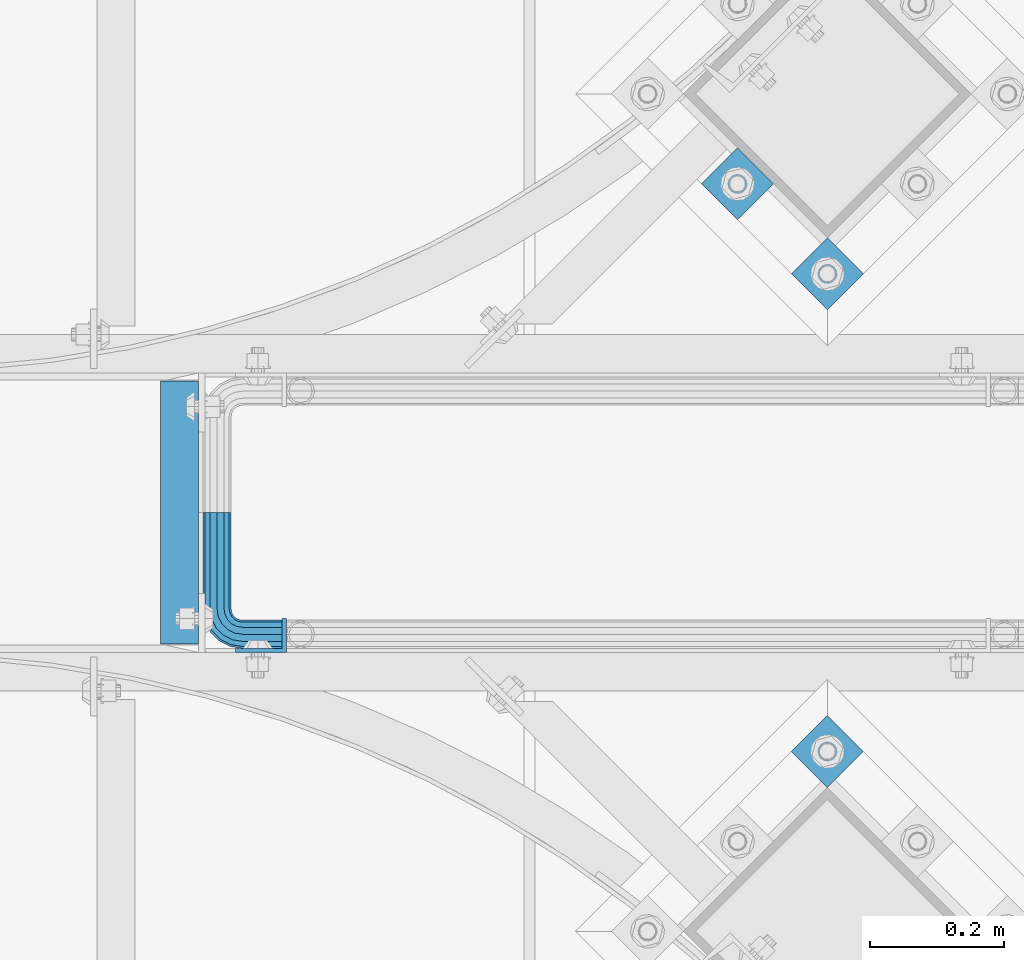
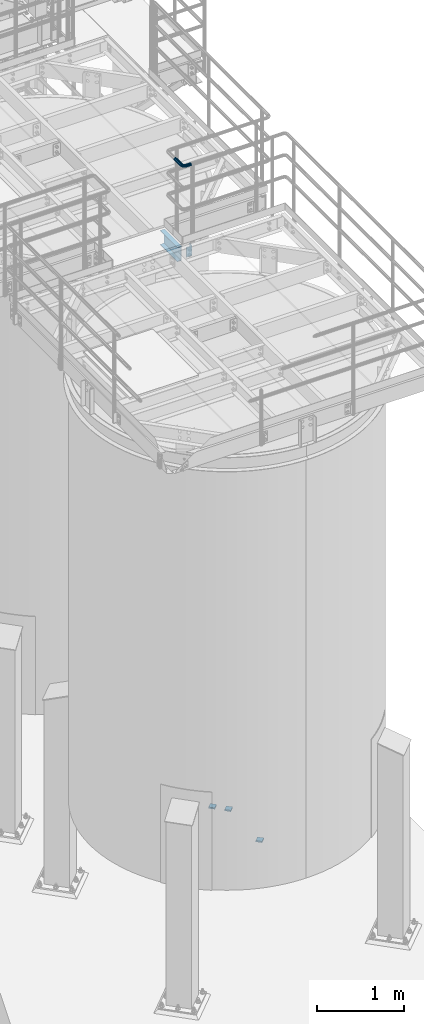
# One storey, part 1118 of 1876: 6 beams, 4 elements without a shape of their own.
"""IFC2X3 building model written with IfcOpenShell, lengths in millimetres."""

from ifc_helpers import new_model, si_unit, frame, origin_with_axes, place, context, subcontext, project, spatial, faceted_brep, material, type_object, element, aggregate, save


model = new_model("IFC2X3")

# Units and contexts
model_context = context("Model", 3, precision=1e-05, world=origin_with_axes())
body_context = subcontext(model_context, "Body", "Model", "MODEL_VIEW")
ifc_project = project(units=[si_unit("LENGTHUNIT", "METRE", prefix="MILLI"), si_unit("AREAUNIT", "SQUARE_METRE"), si_unit("VOLUMEUNIT", "CUBIC_METRE"), si_unit("MASSUNIT", "GRAM", prefix="KILO"), si_unit("TIMEUNIT", "SECOND"), si_unit("PLANEANGLEUNIT", "RADIAN"), si_unit("SOLIDANGLEUNIT", "STERADIAN"), si_unit("THERMODYNAMICTEMPERATUREUNIT", "DEGREE_CELSIUS"), si_unit("LUMINOUSINTENSITYUNIT", "LUMEN")], contexts=[model_context])

# Site, building, storey
site_placement = place(None, origin_with_axes())
site = spatial("IfcSite", under=ifc_project, at=site_placement, CompositionType="ELEMENT")
building_placement = place(site_placement, origin_with_axes())
building = spatial("IfcBuilding", under=site, at=building_placement, Name="Undefined", CompositionType="ELEMENT")
storey_placement = place(building_placement, origin_with_axes())
storey = spatial("IfcBuildingStorey", under=building, at=storey_placement, Name="Undefined", CompositionType="ELEMENT", Elevation=0.0)

# Assembly, beams
assembly_1_placement = place(storey_placement, origin_with_axes())
assembly_1 = element("IfcElementAssembly", 1, at=assembly_1_placement, inside=storey, Name="HANDRAIL", AssemblyPlace="NOTDEFINED", PredefinedType="RIGID_FRAME")
ifc_material_1 = material()
beam_type_1 = type_object("IfcBeamType", Name="PIPE1-1/4STD", PredefinedType="NOTDEFINED")
beam_1_placement = place(assembly_1_placement, frame((5666.23343150122, -11563.31485742, 9090.025), z_axis=(0.0, 0.0, -1.0), x_axis=(0.0, -1.0, 0.0)))
beam_1 = element("IfcBeam", 2, at=beam_1_placement, type_object=beam_type_1, material=ifc_material_1, Name="HANDRAIL", ObjectType="PIPE1-1/4STD", context=body_context, shape_type="Brep", body=[
    faceted_brep([(9.09494701772928e-13, -21.0820000000003, 0.0), (0.0, -18.2575475625836, -10.5409999999993), (144.017601013184, -18.2575475625854, -10.5409999999993), (144.017601013184, -21.0820000000012, 0.0), (0.0, -10.5410000000002, -18.2575475625836), (144.017601013184, -10.5410000000011, -18.2575475625836), (-4.28826751885936e-09, 0.0, -21.0820000000003), (144.017601013184, -1.81898940354586e-12, -21.0820000000003), (0.0, 10.5410000000002, -18.2575475625836), (144.017601013184, 10.5409999999983, -18.2575475625836), (0.0, 18.2575475625836, -10.5409999999993), (144.017601013184, 18.2575475625817, -10.5409999999993), (9.09494701772928e-13, 21.0820000000003, 0.0), (144.017601013184, 21.0819999999985, 0.0), (0.0, 18.2575475625836, 10.5409999999993), (144.017601013184, 18.2575475625817, 10.5409999999993), (0.0, 10.5410000000002, 18.2575475625836), (144.017601013184, 10.5409999999983, 18.2575475625836), (0.0, 0.0, 21.0820000000003), (144.017601013184, -1.81898940354586e-12, 21.0820000000003), (0.0, -10.5410000000002, 18.2575475625836), (144.017601013184, -10.5410000000011, 18.2575475625836), (0.0, -18.2575475625836, 10.5409999999993), (144.017601013184, -18.2575475625854, 10.5409999999993), (0.0, -17.5259999999998, 0.0), (0.0, -15.1779612267264, 8.76300000000083), (144.017601013184, -15.1779612267273, 8.76300000000083), (144.017601013184, -17.5260000000017, 0.0), (0.0, -8.76299999999992, 15.1779612267255), (144.017601013184, -8.76300000000174, 15.1779612267255), (0.0, 0.0, 17.5259999999998), (144.017601013184, -1.81898940354586e-12, 17.5259999999998), (0.0, 8.76299999999992, 15.1779612267255), (144.017601013184, 8.76299999999901, 15.1779612267255), (0.0, 15.1779612267264, 8.76300000000083), (144.017601013184, 15.1779612267246, 8.76300000000083), (0.0, 17.5259999999998, 0.0), (144.017601013184, 17.5259999999989, 0.0), (0.0, 15.1779612267264, -8.76300000000083), (144.017601013184, 15.1779612267246, -8.76300000000083), (0.0, 8.76299999999992, -15.1779612267255), (144.017601013184, 8.76299999999901, -15.1779612267255), (0.0, 0.0, -17.5259999999998), (144.017601013184, -1.81898940354586e-12, -17.5259999999998), (0.0, -8.76299999999992, -15.1779612267255), (144.017601013184, -8.76300000000174, -15.1779612267255), (0.0, -15.1779612267264, -8.76300000000083), (144.017601013184, -15.1779612267273, -8.76300000000083), (149.276451751935, -21.9149201310092, 0.0), (150.149255554901, -19.2287062354389, 10.5409999999993), (152.533799889643, -11.8898333927427, 18.2575475625836), (155.791148027351, -1.86474665447531, 21.0820000000003), (159.048496165058, 8.1603400837912, 18.2575475625836), (161.4330404998, 15.4992129264874, 10.5409999999993), (162.305844302766, 18.1854268220586, 0.0), (161.4330404998, 15.4992129264874, -10.5409999999993), (159.048496165058, 8.1603400837912, -18.2575475625836), (155.791148027351, -1.86474665447531, -21.0820000000003), (152.533799889643, -11.8898333927427, -18.2575475625836), (150.149255554901, -19.2287062354389, -10.5409999999993), (161.206979870767, 14.8034698501133, 0.0), (160.481395986375, 12.570352274277, 8.76300000000083), (158.499063949059, 6.46936159781853, 15.1779612267255), (155.791148027351, -1.86474665447531, 17.5259999999998), (153.083232105642, -10.1988549067692, 15.1779612267255), (151.100900068326, -16.2998455832276, 8.76300000000083), (150.375316183934, -18.5329631590639, 0.0), (151.100900068326, -16.2998455832276, -8.76300000000083), (153.083232105642, -10.1988549067701, -15.1779612267255), (155.791148027351, -1.86474665447531, -17.5259999999998), (158.499063949059, 6.46936159781853, -15.1779612267255), (160.481395986375, 12.570352274277, -8.76300000000083), (172.608062573056, 1.25139591480547, 18.2575475625836), (177.143735428957, 7.49421403083761, 10.5409999999993), (166.412218228641, -7.27645222290084, 21.0820000000003), (160.216373884225, -15.8043003606062, 18.2575475625836), (155.680701028325, -22.0471184766393, 10.5409999999993), (154.02052953981, -24.3321484983126, 0.0), (155.680701028325, -22.0471184766393, -10.5409999999993), (160.216373884225, -15.8043003606062, -18.2575475625836), (166.412218228641, -7.27645222290084, -21.0820000000003), (172.608062573056, 1.25139591480547, -18.2575475625836), (177.143735428957, 7.49421403083761, -10.5409999999993), (178.803906917472, 9.77924405251179, 0.0), (175.333599997579, 5.00277634948452, -8.76300000000083), (176.71374256032, 6.90237962051469, 0.0), (171.562980394479, -0.187036301193075, -15.1779612267255), (166.412218228641, -7.27645222290084, -17.5259999999998), (161.261456062801, -14.3658681446077, -15.1779612267255), (157.490836459703, -19.5556807952853, -8.76300000000083), (156.110693896962, -21.4552840663155, 0.0), (157.490836459703, -19.5556807952853, 8.76300000000083), (161.261456062801, -14.3658681446077, 15.1779612267255), (166.412218228641, -7.27645222290084, 17.5259999999998), (171.562980394479, -0.187036301193075, 15.1779612267255), (175.333599997579, 5.00277634948452, 8.76300000000083), (183.368995402116, -9.50953691425457, 18.2575475625836), (189.611813518148, -4.97386405835459, 10.5409999999993), (174.841147264409, -15.7053812586691, 21.0820000000003), (166.313299126703, -21.9012256030846, 18.2575475625836), (160.070481010669, -26.4368984589846, 10.5409999999993), (157.785450988997, -28.0970699474992, 0.0), (160.070481010669, -26.4368984589846, -10.5409999999993), (166.313299126703, -21.9012256030846, -18.2575475625836), (174.841147264409, -15.7053812586691, -21.0820000000003), (183.368995402116, -9.50953691425457, -18.2575475625836), (189.611813518148, -4.97386405835459, -10.5409999999993), (191.896843539822, -3.31369256983999, 0.0), (187.120375836796, -6.78399948973311, -8.76300000000083), (189.019979107825, -5.40385692699238, 0.0), (181.930563186117, -10.5546190928308, -15.1779612267255), (174.841147264409, -15.7053812586691, -17.5259999999998), (167.751731342702, -20.8561434245084, -15.1779612267255), (162.561918692023, -24.6267630276061, -8.76300000000083), (160.662315420994, -26.0069055903468, 0.0), (162.561918692023, -24.6267630276061, 8.76300000000083), (167.751731342702, -20.8561434245084, 15.1779612267255), (174.841147264409, -15.7053812586691, 17.5259999999998), (181.930563186117, -10.5546190928308, 15.1779612267255), (187.120375836796, -6.78399948973311, 8.76300000000083), (190.277939571099, -23.0691033222465, 18.2575475625836), (197.616812413795, -20.6845589875047, 10.5409999999993), (180.252852832831, -26.3264514599541, 21.0820000000003), (170.227766094566, -29.5837995976626, 18.2575475625836), (162.888893251869, -31.9683439324044, 10.5409999999993), (160.202679356298, -32.8411477353702, 0.0), (162.888893251869, -31.9683439324044, -10.5409999999993), (170.227766094566, -29.5837995976626, -18.2575475625836), (180.252852832831, -26.3264514599541, -21.0820000000003), (190.277939571099, -23.0691033222465, -18.2575475625836), (197.616812413795, -20.6845589875047, -10.5409999999993), (200.303026309366, -19.811755184538, 0.0), (194.687951761583, -21.6362035009297, -8.76300000000083), (196.921069337421, -20.9106196165367, 0.0), (188.586961085126, -23.6185355382449, -15.1779612267255), (180.252852832831, -26.3264514599541, -17.5259999999998), (171.918744580538, -29.0343673816633, -15.1779612267255), (165.817753904079, -31.0166994189794, -8.76300000000083), (163.584636328244, -31.7422833033725, 0.0), (165.817753904079, -31.0166994189794, 8.76300000000083), (171.918744580538, -29.0343673816633, 15.1779612267255), (180.252852832831, -26.3264514599541, 17.5259999999998), (188.586961085126, -23.6185355382449, 15.1779612267255), (194.687951761583, -21.6362035009297, 8.76300000000083), (171.576599487307, -38.0999984741229, -18.2575475625836), (163.860051924723, -38.0999984741229, -10.5409999999993), (182.117599487307, -38.099998474122, -21.0820000000003), (192.658599487306, -38.099998474122, -18.2575475625836), (200.37514704989, -38.099998474122, -10.5409999999993), (203.199599487307, -38.099998474122, 0.0), (200.37514704989, -38.099998474122, 10.5409999999993), (192.658599487306, -38.099998474122, 18.2575475625836), (182.117599487307, -38.099998474122, 21.0820000000003), (171.576599487307, -38.0999984741229, 18.2575475625836), (163.860051924723, -38.0999984741229, 10.5409999999993), (161.035599487304, -38.0999984741229, 0.0), (197.295560714032, -38.099998474122, -8.76300000000083), (199.643599487306, -38.099998474122, 0.0), (190.880599487307, -38.099998474122, -15.1779612267255), (182.117599487307, -38.099998474122, -17.5259999999998), (173.354599487306, -38.0999984741229, -15.1779612267255), (166.939638260581, -38.0999984741229, -8.76300000000083), (164.591599487305, -38.0999984741229, 0.0), (166.939638260581, -38.0999984741229, 8.76300000000083), (173.354599487306, -38.0999984741229, 15.1779612267255), (182.117599487307, -38.099998474122, 17.5259999999998), (190.880599487307, -38.099998474122, 15.1779612267255), (197.295560714032, -38.099998474122, 8.76300000000083), (163.860051924721, -103.933624267578, -10.5409999999993), (161.035599487304, -103.933624267578, 0.0), (171.576599487305, -103.933624267578, -18.2575475625836), (182.117599487305, -103.933624267578, -21.0820000000003), (192.658599487304, -103.933624267578, -18.2575475625836), (200.375147049888, -103.933624267578, -10.5409999999993), (203.199599487305, -103.933624267578, 0.0), (200.375147049888, -103.933624267578, 10.5409999999993), (192.658599487304, -103.933624267578, 18.2575475625836), (182.117599487305, -103.933624267578, 21.0820000000003), (171.576599487305, -103.933624267578, 18.2575475625836), (163.860051924721, -103.933624267578, 10.5409999999993), (166.939638260579, -103.933624267578, 8.76300000000083), (164.591599487305, -103.933624267578, 0.0), (173.354599487304, -103.933624267578, 15.1779612267255), (182.117599487305, -103.933624267578, 17.5259999999998), (190.880599487306, -103.933624267578, 15.1779612267255), (197.29556071403, -103.933624267578, 8.76300000000083), (199.643599487305, -103.933624267578, 0.0), (197.29556071403, -103.933624267578, -8.76300000000083), (190.880599487306, -103.933624267578, -15.1779612267255), (182.117599487305, -103.933624267578, -17.5259999999998), (173.354599487304, -103.933624267578, -15.1779612267255), (166.939638260579, -103.933624267578, -8.76300000000083)], [[[0, 1, 2, 3]], [[1, 4, 5, 2]], [[4, 6, 7, 5]], [[6, 8, 9, 7]], [[8, 10, 11, 9]], [[10, 12, 13, 11]], [[12, 14, 15, 13]], [[14, 16, 17, 15]], [[16, 18, 19, 17]], [[18, 20, 21, 19]], [[20, 22, 23, 21]], [[22, 0, 3, 23]], [[24, 25, 26, 27]], [[25, 28, 29, 26]], [[28, 30, 31, 29]], [[30, 32, 33, 31]], [[32, 34, 35, 33]], [[34, 36, 37, 35]], [[36, 38, 39, 37]], [[38, 40, 41, 39]], [[40, 42, 43, 41]], [[42, 44, 45, 43]], [[44, 46, 47, 45]], [[46, 24, 27, 47]], [[22, 20, 18, 16, 14, 12, 10, 8, 6, 4, 1, 0], [46, 44, 42, 40, 38, 36, 34, 32, 30, 28, 25, 24]], [[23, 3, 48, 49]], [[21, 23, 49, 50]], [[19, 21, 50, 51]], [[17, 19, 51, 52]], [[15, 17, 52, 53]], [[13, 15, 53, 54]], [[11, 13, 54, 55]], [[9, 11, 55, 56]], [[7, 9, 56, 57]], [[5, 7, 57, 58]], [[2, 5, 58, 59]], [[3, 2, 59, 48]], [[35, 37, 60, 61]], [[33, 35, 61, 62]], [[31, 33, 62, 63]], [[29, 31, 63, 64]], [[26, 29, 64, 65]], [[27, 26, 65, 66]], [[47, 27, 66, 67]], [[45, 47, 67, 68]], [[43, 45, 68, 69]], [[41, 43, 69, 70]], [[39, 41, 70, 71]], [[37, 39, 71, 60]], [[52, 72, 73, 53]], [[51, 74, 72, 52]], [[50, 75, 74, 51]], [[49, 76, 75, 50]], [[48, 77, 76, 49]], [[59, 78, 77, 48]], [[58, 79, 78, 59]], [[57, 80, 79, 58]], [[56, 81, 80, 57]], [[55, 82, 81, 56]], [[54, 83, 82, 55]], [[53, 73, 83, 54]], [[71, 84, 85, 60]], [[70, 86, 84, 71]], [[69, 87, 86, 70]], [[68, 88, 87, 69]], [[67, 89, 88, 68]], [[66, 90, 89, 67]], [[65, 91, 90, 66]], [[64, 92, 91, 65]], [[63, 93, 92, 64]], [[62, 94, 93, 63]], [[61, 95, 94, 62]], [[60, 85, 95, 61]], [[72, 96, 97, 73]], [[74, 98, 96, 72]], [[75, 99, 98, 74]], [[76, 100, 99, 75]], [[77, 101, 100, 76]], [[78, 102, 101, 77]], [[79, 103, 102, 78]], [[80, 104, 103, 79]], [[81, 105, 104, 80]], [[82, 106, 105, 81]], [[83, 107, 106, 82]], [[73, 97, 107, 83]], [[84, 108, 109, 85]], [[86, 110, 108, 84]], [[87, 111, 110, 86]], [[88, 112, 111, 87]], [[89, 113, 112, 88]], [[90, 114, 113, 89]], [[91, 115, 114, 90]], [[92, 116, 115, 91]], [[93, 117, 116, 92]], [[94, 118, 117, 93]], [[95, 119, 118, 94]], [[85, 109, 119, 95]], [[96, 120, 121, 97]], [[98, 122, 120, 96]], [[99, 123, 122, 98]], [[100, 124, 123, 99]], [[101, 125, 124, 100]], [[102, 126, 125, 101]], [[103, 127, 126, 102]], [[104, 128, 127, 103]], [[105, 129, 128, 104]], [[106, 130, 129, 105]], [[107, 131, 130, 106]], [[97, 121, 131, 107]], [[108, 132, 133, 109]], [[110, 134, 132, 108]], [[111, 135, 134, 110]], [[112, 136, 135, 111]], [[113, 137, 136, 112]], [[114, 138, 137, 113]], [[115, 139, 138, 114]], [[116, 140, 139, 115]], [[117, 141, 140, 116]], [[118, 142, 141, 117]], [[119, 143, 142, 118]], [[109, 133, 143, 119]], [[127, 144, 145, 126]], [[128, 146, 144, 127]], [[129, 147, 146, 128]], [[130, 148, 147, 129]], [[131, 149, 148, 130]], [[121, 150, 149, 131]], [[120, 151, 150, 121]], [[122, 152, 151, 120]], [[123, 153, 152, 122]], [[124, 154, 153, 123]], [[125, 155, 154, 124]], [[126, 145, 155, 125]], [[132, 156, 157, 133]], [[134, 158, 156, 132]], [[135, 159, 158, 134]], [[136, 160, 159, 135]], [[137, 161, 160, 136]], [[138, 162, 161, 137]], [[139, 163, 162, 138]], [[140, 164, 163, 139]], [[141, 165, 164, 140]], [[142, 166, 165, 141]], [[143, 167, 166, 142]], [[133, 157, 167, 143]], [[155, 145, 168, 169]], [[145, 144, 170, 168]], [[144, 146, 171, 170]], [[146, 147, 172, 171]], [[147, 148, 173, 172]], [[148, 149, 174, 173]], [[149, 150, 175, 174]], [[150, 151, 176, 175]], [[151, 152, 177, 176]], [[152, 153, 178, 177]], [[153, 154, 179, 178]], [[154, 155, 169, 179]], [[162, 163, 180, 181]], [[163, 164, 182, 180]], [[164, 165, 183, 182]], [[165, 166, 184, 183]], [[166, 167, 185, 184]], [[167, 157, 186, 185]], [[157, 156, 187, 186]], [[156, 158, 188, 187]], [[158, 159, 189, 188]], [[159, 160, 190, 189]], [[160, 161, 191, 190]], [[161, 162, 181, 191]], [[170, 171, 172, 173, 174, 175, 176, 177, 178, 179, 169, 168], [182, 183, 184, 185, 186, 187, 188, 189, 190, 191, 181, 180]]]),
])
ifc_material_2 = material(Name="STEEL/A36")
beam_type_2 = type_object("IfcBeamType", Name="L3X2X1/4", PredefinedType="NOTDEFINED")
beam_2_placement = place(assembly_1_placement, frame((5732.01943150122, -11747.4644531238, 7966.075), z_axis=(-1.0, 0.0, 0.0), x_axis=(0.0, 0.0, -1.0)))
beam_2 = element("IfcBeam", 3, at=beam_2_placement, type_object=beam_type_2, material=ifc_material_2, Name="ANGLE", ObjectType="L3X2X1/4", context=body_context, shape_type="Brep", body=[
    faceted_brep([(0.0, 25.3999999999996, -38.1000000000004), (0.0, 25.3999999999996, 38.1000000000004), (139.7, 25.3999999999996, 38.1000000000004), (139.7, 25.3999999999996, -38.1000000000004), (0.0, 19.0500000000002, 38.1000000000004), (139.7, 19.0500000000002, 38.1000000000004), (0.0, 19.0500000000002, -31.75), (139.7, 19.0500000000002, -31.75), (0.0, -25.3999999999996, -31.75), (139.7, -25.3999999999996, -31.75), (0.0, -25.3999999999996, -38.1000000000004), (139.7, -25.3999999999996, -38.1000000000004)], [[[0, 1, 2, 3]], [[1, 4, 5, 2]], [[4, 6, 7, 5]], [[6, 8, 9, 7]], [[8, 10, 11, 9]], [[10, 0, 3, 11]], [[5, 7, 9, 11, 3, 2]], [[10, 8, 6, 4, 1, 0]]]),
])
aggregate(assembly_1, [beam_1, beam_2])

# Assembly, beam
assembly_2_placement = place(storey_placement, origin_with_axes())
assembly_2 = element("IfcElementAssembly", 4, at=assembly_2_placement, inside=storey, Name="BEAM", AssemblyPlace="NOTDEFINED", PredefinedType="RIGID_FRAME")
beam_type_3 = type_object("IfcBeamType", Name="C8X11.5", PredefinedType="NOTDEFINED")
beam_3_placement = place(assembly_2_placement, frame((5610.22643150122, -11772.8644531238, 7896.225), z_axis=(0.0, 0.0, -1.0), x_axis=(0.0, 1.0, 0.0)))
beam_3 = element("IfcBeam", 5, at=beam_3_placement, type_object=beam_type_3, material=ifc_material_2, Name="BEAM", ObjectType="C8X11.5", context=body_context, shape_type="Brep", body=[
    faceted_brep([(12.7000000000007, 28.5749999999998, -101.6), (12.7000000000007, 28.5749999999998, 101.6), (406.400097655021, 28.5749999999998, 101.6), (406.400097655021, 28.5749999999998, -101.6), (12.7000000000007, -28.5749999999998, 101.6), (406.400097655021, -28.5749999999998, 101.6), (12.7000000000007, -28.5749999999998, 96.8355949999996), (406.400097655021, -28.5749999999998, 96.8355949999996), (12.7000000000007, 22.2250000000004, 88.3723149999996), (406.400097655021, 22.2250000000004, 88.3723149999996), (12.7000000000007, 22.2250000000004, -88.3723149999996), (406.400097655021, 22.2250000000004, -88.3723149999996), (12.7000000000007, -28.5749999999998, -96.8355949999996), (406.400097655021, -28.5749999999998, -96.8355949999996), (12.7000000000007, -28.5749999999998, -101.6), (406.400097655021, -28.5749999999998, -101.6)], [[[0, 1, 2, 3]], [[1, 4, 5, 2]], [[4, 6, 7, 5]], [[6, 8, 9, 7]], [[8, 10, 11, 9]], [[10, 12, 13, 11]], [[12, 14, 15, 13]], [[14, 0, 3, 15]], [[5, 7, 9, 11, 13, 15, 3, 2]], [[14, 12, 10, 8, 6, 4, 1, 0]]]),
])
aggregate(assembly_2, [beam_3])

assembly_3_placement = place(storey_placement, origin_with_axes())
assembly_3 = element("IfcElementAssembly", 6, at=assembly_3_placement, inside=storey, Name="TEMPLATE", AssemblyPlace="NOTDEFINED", PredefinedType="RIGID_FRAME")
beam_type_4 = type_object("IfcBeamType", PredefinedType="NOTDEFINED")
beam_4_placement = place(assembly_3_placement, frame((6607.21565921986, -11893.9766571481, -542.925), z_axis=(-0.707106781186548, 0.707106781186547, 0.0), x_axis=(-0.707106781186547, -0.707106781186548, 0.0)))
beam_4 = element("IfcBeam", 7, at=beam_4_placement, type_object=beam_type_4, material=ifc_material_2, Name="PLATE", context=body_context, shape_type="Brep", body=[
    faceted_brep([(0.0, 9.52499999999998, -38.1000000000058), (-9.09494701772928e-13, 9.52499999999998, 38.1000000000076), (76.2000000000762, 9.52499999999998, 38.1000000000058), (76.2000000000762, 9.52499999999998, -38.1000000000058), (-9.09494701772928e-13, -9.52499999999998, 38.1000000000076), (76.2000000000762, -9.52499999999998, 38.1000000000058), (0.0, -9.52499999999998, -38.1000000000058), (76.2000000000762, -9.52499999999998, -38.1000000000058)], [[[0, 1, 2, 3]], [[1, 4, 5, 2]], [[4, 6, 7, 5]], [[6, 0, 3, 7]], [[5, 7, 3, 2]], [[6, 4, 1, 0]]]),
])
aggregate(assembly_3, [beam_4])

# Assembly, beams
assembly_4_placement = place(storey_placement, origin_with_axes())
assembly_4 = element("IfcElementAssembly", 8, at=assembly_4_placement, inside=storey, Name="TEMPLATE", AssemblyPlace="NOTDEFINED", PredefinedType="RIGID_FRAME")
beam_5_placement = place(assembly_4_placement, frame((6607.21897365624, -11178.6993056794, -542.925), z_axis=(-0.707106781186548, 0.707106781186547, 0.0), x_axis=(-0.707106781186547, -0.707106781186548, 0.0)))
beam_5 = element("IfcBeam", 9, at=beam_5_placement, type_object=beam_type_4, material=ifc_material_2, Name="PLATE", context=body_context, shape_type="Brep", body=[
    faceted_brep([(0.0, 9.52499999999998, -38.1000000000058), (-9.09494701772928e-13, 9.52499999999998, 38.1000000000076), (76.2000000000762, 9.52499999999998, 38.1000000000058), (76.2000000000762, 9.52499999999998, -38.1000000000058), (-9.09494701772928e-13, -9.52499999999998, 38.1000000000076), (76.2000000000762, -9.52499999999998, 38.1000000000058), (0.0, -9.52499999999998, -38.1000000000058), (76.2000000000762, -9.52499999999998, -38.1000000000058)], [[[0, 1, 2, 3]], [[1, 4, 5, 2]], [[4, 6, 7, 5]], [[6, 0, 3, 7]], [[5, 7, 3, 2]], [[6, 4, 1, 0]]]),
])
beam_6_placement = place(assembly_4_placement, frame((6472.51513184009, -11043.9954638633, -542.925), z_axis=(-0.707106781186548, 0.707106781186547, 0.0), x_axis=(-0.707106781186547, -0.707106781186548, 0.0)))
beam_6 = element("IfcBeam", 10, at=beam_6_placement, type_object=beam_type_4, material=ifc_material_2, Name="PLATE", context=body_context, shape_type="Brep", body=[
    faceted_brep([(0.0, 9.52499999999998, -38.1000000000058), (-9.09494701772928e-13, 9.52499999999998, 38.1000000000076), (76.2000000000762, 9.52499999999998, 38.1000000000058), (76.2000000000762, 9.52499999999998, -38.1000000000058), (-9.09494701772928e-13, -9.52499999999998, 38.1000000000076), (76.2000000000762, -9.52499999999998, 38.1000000000058), (0.0, -9.52499999999998, -38.1000000000058), (76.2000000000762, -9.52499999999998, -38.1000000000058)], [[[0, 1, 2, 3]], [[1, 4, 5, 2]], [[4, 6, 7, 5]], [[6, 0, 3, 7]], [[5, 7, 3, 2]], [[6, 4, 1, 0]]]),
])
aggregate(assembly_4, [beam_5, beam_6])

save(model, "model.ifc")
